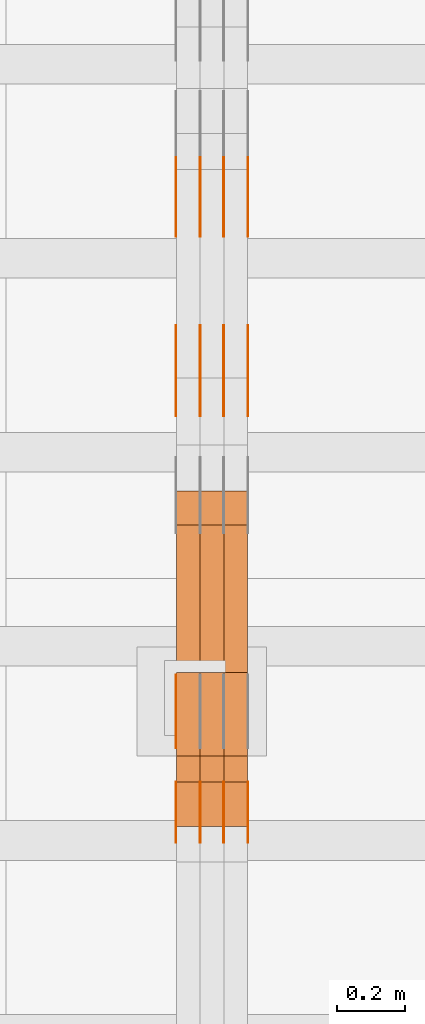
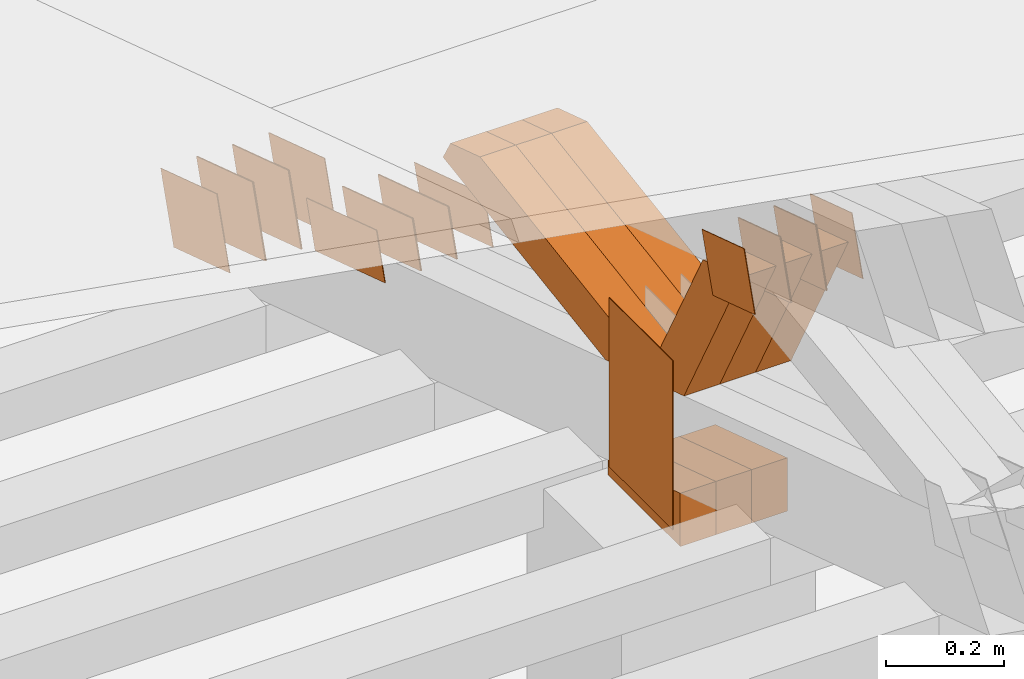
# One storey, part 106 of 385: 28 proxies.
"""IFC2X3 building model written with IfcOpenShell, lengths in millimetres."""

from ifc_helpers import new_model, entity, si_unit, converted_unit, derived_unit, direction, frame, origin, origin_2d_with_axis, place, context, subcontext, project, spatial, polyline, rectangle, outline, extrude, source, transform, mapped, material, type_object, type_shapes, element, save


model = new_model("IFC2X3")

# Units and contexts
model_context = context("Model", 3, precision=0.01, world=origin(), true_north=direction((6.12303176911189e-17, 1.0)))
body_context = subcontext(model_context, "Body", "Model", "MODEL_VIEW")
ifc_project = project(units=[si_unit("LENGTHUNIT", "METRE", prefix="MILLI"), si_unit("AREAUNIT", "SQUARE_METRE"), si_unit("VOLUMEUNIT", "CUBIC_METRE"), converted_unit("PLANEANGLEUNIT", "DEGREE", entity("IfcRatioMeasure", 0.0174532925199433), si_unit("PLANEANGLEUNIT", "RADIAN"), dimensions=[0, 0, 0, 0, 0, 0, 0]), si_unit("MASSUNIT", "GRAM", prefix="KILO"), derived_unit("MASSDENSITYUNIT", [(si_unit("MASSUNIT", "GRAM", prefix="KILO"), 1), (si_unit("LENGTHUNIT", "METRE"), -3)]), si_unit("TIMEUNIT", "SECOND"), si_unit("FREQUENCYUNIT", "HERTZ"), si_unit("THERMODYNAMICTEMPERATUREUNIT", "DEGREE_CELSIUS"), derived_unit("THERMALTRANSMITTANCEUNIT", [(si_unit("MASSUNIT", "GRAM", prefix="KILO"), 1), (si_unit("THERMODYNAMICTEMPERATUREUNIT", "KELVIN"), -1), (si_unit("TIMEUNIT", "SECOND"), -3)]), derived_unit("VOLUMETRICFLOWRATEUNIT", [(si_unit("LENGTHUNIT", "METRE"), 3), (si_unit("TIMEUNIT", "SECOND"), -1)]), si_unit("ELECTRICCURRENTUNIT", "AMPERE"), si_unit("ELECTRICVOLTAGEUNIT", "VOLT"), si_unit("POWERUNIT", "WATT"), si_unit("FORCEUNIT", "NEWTON", prefix="KILO"), si_unit("ILLUMINANCEUNIT", "LUX"), si_unit("LUMINOUSFLUXUNIT", "LUMEN"), si_unit("LUMINOUSINTENSITYUNIT", "CANDELA"), derived_unit("USERDEFINED", [(si_unit("MASSUNIT", "GRAM", prefix="KILO"), -1), (si_unit("LENGTHUNIT", "METRE"), -2), (si_unit("TIMEUNIT", "SECOND"), 3), (si_unit("LUMINOUSFLUXUNIT", "LUMEN"), 1)]), derived_unit("LINEARVELOCITYUNIT", [(si_unit("LENGTHUNIT", "METRE"), 1), (si_unit("TIMEUNIT", "SECOND"), -1)]), si_unit("PRESSUREUNIT", "PASCAL"), derived_unit("USERDEFINED", [(si_unit("LENGTHUNIT", "METRE"), -2), (si_unit("MASSUNIT", "GRAM", prefix="KILO"), 1), (si_unit("TIMEUNIT", "SECOND"), -2)])], contexts=[model_context])

# Site, building, storey
site_placement = place(None, origin())
site = spatial("IfcSite", under=ifc_project, at=site_placement, CompositionType="ELEMENT")
building_placement = place(site_placement, origin())
building = spatial("IfcBuilding", under=site, at=building_placement, CompositionType="ELEMENT")
storey_placement = place(building_placement, origin())
storey = spatial("IfcBuildingStorey", under=building, at=storey_placement, Name="Default", CompositionType="ELEMENT", Elevation=0.0)

# Proxies
ifc_material_1 = material(Name="IfcSurfaceStyle #204694")
building_element_proxy_type_1 = type_object("IfcBuildingElementProxyType", PredefinedType="NOTDEFINED", material=ifc_material_1)
shared_shape_1 = source(origin(), body_context, "Body", "SweptSolid", [
    extrude(outline(polyline([(-125.00031378339, -47.9999612158856), (125.000225258022, -47.9999612158856), (124.999811678525, 47.9999612158856), (-124.999723153156, 47.9999612158856), (-125.00031378339, -47.9999612158856)])), frame((125.000225258022, 48.0000091013474, 0.0), z_axis=(0.0, 0.0, 1.0), x_axis=(-1.0, 0.0, 0.0)), (0.0, 0.0, 1.0), 1.3),
])
type_shapes(building_element_proxy_type_1, [shared_shape_1])
proxy_1_placement = place(building_placement, frame((15386.3, 18456.8597683375, 2657.46691321253), z_axis=(-1.0, 0.0, 0.0), x_axis=(0.0, -0.951056516295124, 0.309016994375039)))
element("IfcBuildingElementProxy", 1, at=proxy_1_placement, inside=storey, type_object=building_element_proxy_type_1, material=ifc_material_1, context=body_context, shape_type="MappedRepresentation", body=[
    mapped(shared_shape_1, transform((0.0, 0.0, 0.0), scale=1.0)),
])
ifc_material_2 = material(Name="IfcSurfaceStyle #204637")
building_element_proxy_type_2 = type_object("IfcBuildingElementProxyType", PredefinedType="NOTDEFINED", material=ifc_material_2)
shared_shape_2 = source(origin(), body_context, "Body", "SweptSolid", [
    extrude(outline(polyline([(-125.00031378339, -47.9999612158856), (125.000225258022, -47.9999612158856), (124.999811678525, 47.9999612158856), (-124.999723153156, 47.9999612158856), (-125.00031378339, -47.9999612158856)])), frame((125.000225258022, 48.0000091013474, 0.0), z_axis=(0.0, 0.0, 1.0), x_axis=(-1.0, 0.0, 0.0)), (0.0, 0.0, 1.0), 1.3),
])
type_shapes(building_element_proxy_type_2, [shared_shape_2])
proxy_2_placement = place(building_placement, frame((15315.0, 18456.8597683375, 2657.46691321253), z_axis=(-1.0, 0.0, 0.0), x_axis=(0.0, -0.951056516295124, 0.309016994375039)))
element("IfcBuildingElementProxy", 2, at=proxy_2_placement, inside=storey, type_object=building_element_proxy_type_2, material=ifc_material_2, context=body_context, shape_type="MappedRepresentation", body=[
    mapped(shared_shape_2, transform((0.0, 0.0, 0.0), scale=1.0)),
])
ifc_material_3 = material(Name="IfcSurfaceStyle #204580")
building_element_proxy_type_3 = type_object("IfcBuildingElementProxyType", PredefinedType="NOTDEFINED", material=ifc_material_3)
shared_shape_3 = source(origin(), body_context, "Body", "SweptSolid", [
    extrude(outline(polyline([(-125.00031378339, -47.9999612158856), (125.000225258022, -47.9999612158856), (124.999811678525, 47.9999612158856), (-124.999723153156, 47.9999612158856), (-125.00031378339, -47.9999612158856)])), frame((125.000225258022, 48.0000091013474, 0.0), z_axis=(0.0, 0.0, 1.0), x_axis=(-1.0, 0.0, 0.0)), (0.0, 0.0, 1.0), 1.3),
])
type_shapes(building_element_proxy_type_3, [shared_shape_3])
proxy_3_placement = place(building_placement, frame((15316.3, 18456.8597683375, 2657.46691321253), z_axis=(-1.0, 0.0, 0.0), x_axis=(0.0, -0.951056516295124, 0.309016994375039)))
element("IfcBuildingElementProxy", 3, at=proxy_3_placement, inside=storey, type_object=building_element_proxy_type_3, material=ifc_material_3, context=body_context, shape_type="MappedRepresentation", body=[
    mapped(shared_shape_3, transform((0.0, 0.0, 0.0), scale=1.0)),
])
ifc_material_4 = material(Name="IfcSurfaceStyle #204523")
building_element_proxy_type_4 = type_object("IfcBuildingElementProxyType", PredefinedType="NOTDEFINED", material=ifc_material_4)
shared_shape_4 = source(origin(), body_context, "Body", "SweptSolid", [
    extrude(outline(polyline([(-125.00031378339, -47.9999612158856), (125.000225258022, -47.9999612158856), (124.999811678525, 47.9999612158856), (-124.999723153156, 47.9999612158856), (-125.00031378339, -47.9999612158856)])), frame((125.000225258022, 48.0000091013474, 0.0), z_axis=(0.0, 0.0, 1.0), x_axis=(-1.0, 0.0, 0.0)), (0.0, 0.0, 1.0), 1.29999999999998),
])
type_shapes(building_element_proxy_type_4, [shared_shape_4])
proxy_4_placement = place(building_placement, frame((15245.0, 18456.8597683375, 2657.46691321253), z_axis=(-1.0, 0.0, 0.0), x_axis=(0.0, -0.951056516295124, 0.309016994375039)))
element("IfcBuildingElementProxy", 4, at=proxy_4_placement, inside=storey, type_object=building_element_proxy_type_4, material=ifc_material_4, context=body_context, shape_type="MappedRepresentation", body=[
    mapped(shared_shape_4, transform((0.0, 0.0, 0.0), scale=1.0)),
])
ifc_material_5 = material(Name="IfcSurfaceStyle #204466")
building_element_proxy_type_5 = type_object("IfcBuildingElementProxyType", PredefinedType="NOTDEFINED", material=ifc_material_5)
shared_shape_5 = source(origin(), body_context, "Body", "SweptSolid", [
    extrude(outline(polyline([(-125.00031378339, -47.9999612158856), (125.000225258022, -47.9999612158856), (124.999811678525, 47.9999612158856), (-124.999723153156, 47.9999612158856), (-125.00031378339, -47.9999612158856)])), frame((125.000225258022, 48.0000091013474, 0.0), z_axis=(0.0, 0.0, 1.0), x_axis=(-1.0, 0.0, 0.0)), (0.0, 0.0, 1.0), 1.29999999999998),
])
type_shapes(building_element_proxy_type_5, [shared_shape_5])
proxy_5_placement = place(building_placement, frame((15246.3, 18456.8597683375, 2657.46691321253), z_axis=(-1.0, 0.0, 0.0), x_axis=(0.0, -0.951056516295124, 0.309016994375039)))
element("IfcBuildingElementProxy", 5, at=proxy_5_placement, inside=storey, type_object=building_element_proxy_type_5, material=ifc_material_5, context=body_context, shape_type="MappedRepresentation", body=[
    mapped(shared_shape_5, transform((0.0, 0.0, 0.0), scale=1.0)),
])
ifc_material_6 = material(Name="IfcSurfaceStyle #204409")
building_element_proxy_type_6 = type_object("IfcBuildingElementProxyType", PredefinedType="NOTDEFINED", material=ifc_material_6)
shared_shape_6 = source(origin(), body_context, "Body", "SweptSolid", [
    extrude(outline(polyline([(-125.00031378339, -47.9999612158856), (125.000225258022, -47.9999612158856), (124.999811678525, 47.9999612158856), (-124.999723153156, 47.9999612158856), (-125.00031378339, -47.9999612158856)])), frame((125.000225258022, 48.0000091013474, 0.0), z_axis=(0.0, 0.0, 1.0), x_axis=(-1.0, 0.0, 0.0)), (0.0, 0.0, 1.0), 1.29999999999998),
])
type_shapes(building_element_proxy_type_6, [shared_shape_6])
proxy_6_placement = place(building_placement, frame((15175.0, 18456.8597683375, 2657.46691321253), z_axis=(-1.0, 0.0, 0.0), x_axis=(0.0, -0.951056516295124, 0.309016994375039)))
element("IfcBuildingElementProxy", 6, at=proxy_6_placement, inside=storey, type_object=building_element_proxy_type_6, material=ifc_material_6, context=body_context, shape_type="MappedRepresentation", body=[
    mapped(shared_shape_6, transform((0.0, 0.0, 0.0), scale=1.0)),
])
ifc_material_7 = material(Name="IfcSurfaceStyle #202984")
building_element_proxy_type_7 = type_object("IfcBuildingElementProxyType", PredefinedType="NOTDEFINED", material=ifc_material_7)
shared_shape_7 = source(origin(), body_context, "Body", "SweptSolid", [
    extrude(outline(polyline([(-99.999796294464, -72.0000050220467), (99.9998768370438, -72.0000050220467), (100.000260677528, 72.0000050220467), (-100.000341220108, 72.0000050220467), (-99.999796294464, -72.0000050220467)])), frame((100.000260677528, 72.0000050220467, 0.0), z_axis=(0.0, 0.0, 1.0), x_axis=(-1.0, 0.0, 0.0)), (0.0, 0.0, 1.0), 1.3),
])
type_shapes(building_element_proxy_type_7, [shared_shape_7])
proxy_7_placement = place(building_placement, frame((15386.3, 18936.3876569477, 2373.90613192527), z_axis=(-1.0, 0.0, 0.0), x_axis=(0.0, -0.951056516295124, 0.309016994375039)))
element("IfcBuildingElementProxy", 7, at=proxy_7_placement, inside=storey, type_object=building_element_proxy_type_7, material=ifc_material_7, context=body_context, shape_type="MappedRepresentation", body=[
    mapped(shared_shape_7, transform((0.0, 0.0, 0.0), scale=1.0)),
])
ifc_material_8 = material(Name="IfcSurfaceStyle #202927")
building_element_proxy_type_8 = type_object("IfcBuildingElementProxyType", PredefinedType="NOTDEFINED", material=ifc_material_8)
shared_shape_8 = source(origin(), body_context, "Body", "SweptSolid", [
    extrude(outline(polyline([(-99.999796294464, -72.0000050220467), (99.9998768370438, -72.0000050220467), (100.000260677528, 72.0000050220467), (-100.000341220108, 72.0000050220467), (-99.999796294464, -72.0000050220467)])), frame((100.000260677528, 72.0000050220467, 0.0), z_axis=(0.0, 0.0, 1.0), x_axis=(-1.0, 0.0, 0.0)), (0.0, 0.0, 1.0), 1.3),
])
type_shapes(building_element_proxy_type_8, [shared_shape_8])
proxy_8_placement = place(building_placement, frame((15315.0, 18936.3876569477, 2373.90613192527), z_axis=(-1.0, 0.0, 0.0), x_axis=(0.0, -0.951056516295124, 0.309016994375039)))
element("IfcBuildingElementProxy", 8, at=proxy_8_placement, inside=storey, type_object=building_element_proxy_type_8, material=ifc_material_8, context=body_context, shape_type="MappedRepresentation", body=[
    mapped(shared_shape_8, transform((0.0, 0.0, 0.0), scale=1.0)),
])
ifc_material_9 = material(Name="IfcSurfaceStyle #202870")
building_element_proxy_type_9 = type_object("IfcBuildingElementProxyType", PredefinedType="NOTDEFINED", material=ifc_material_9)
shared_shape_9 = source(origin(), body_context, "Body", "SweptSolid", [
    extrude(outline(polyline([(-99.999796294464, -72.0000050220467), (99.9998768370438, -72.0000050220467), (100.000260677528, 72.0000050220467), (-100.000341220108, 72.0000050220467), (-99.999796294464, -72.0000050220467)])), frame((100.000260677528, 72.0000050220467, 0.0), z_axis=(0.0, 0.0, 1.0), x_axis=(-1.0, 0.0, 0.0)), (0.0, 0.0, 1.0), 1.3),
])
type_shapes(building_element_proxy_type_9, [shared_shape_9])
proxy_9_placement = place(building_placement, frame((15316.3, 18936.3876569477, 2373.90613192527), z_axis=(-1.0, 0.0, 0.0), x_axis=(0.0, -0.951056516295124, 0.309016994375039)))
element("IfcBuildingElementProxy", 9, at=proxy_9_placement, inside=storey, type_object=building_element_proxy_type_9, material=ifc_material_9, context=body_context, shape_type="MappedRepresentation", body=[
    mapped(shared_shape_9, transform((0.0, 0.0, 0.0), scale=1.0)),
])
ifc_material_10 = material(Name="IfcSurfaceStyle #202813")
building_element_proxy_type_10 = type_object("IfcBuildingElementProxyType", PredefinedType="NOTDEFINED", material=ifc_material_10)
shared_shape_10 = source(origin(), body_context, "Body", "SweptSolid", [
    extrude(outline(polyline([(-99.999796294464, -72.0000050220467), (99.9998768370438, -72.0000050220467), (100.000260677528, 72.0000050220467), (-100.000341220108, 72.0000050220467), (-99.999796294464, -72.0000050220467)])), frame((100.000260677528, 72.0000050220467, 0.0), z_axis=(0.0, 0.0, 1.0), x_axis=(-1.0, 0.0, 0.0)), (0.0, 0.0, 1.0), 1.29999999999998),
])
type_shapes(building_element_proxy_type_10, [shared_shape_10])
proxy_10_placement = place(building_placement, frame((15245.0, 18936.3876569477, 2373.90613192527), z_axis=(-1.0, 0.0, 0.0), x_axis=(0.0, -0.951056516295124, 0.309016994375039)))
element("IfcBuildingElementProxy", 10, at=proxy_10_placement, inside=storey, type_object=building_element_proxy_type_10, material=ifc_material_10, context=body_context, shape_type="MappedRepresentation", body=[
    mapped(shared_shape_10, transform((0.0, 0.0, 0.0), scale=1.0)),
])
ifc_material_11 = material(Name="IfcSurfaceStyle #202756")
building_element_proxy_type_11 = type_object("IfcBuildingElementProxyType", PredefinedType="NOTDEFINED", material=ifc_material_11)
shared_shape_11 = source(origin(), body_context, "Body", "SweptSolid", [
    extrude(outline(polyline([(-99.999796294464, -72.0000050220467), (99.9998768370438, -72.0000050220467), (100.000260677528, 72.0000050220467), (-100.000341220108, 72.0000050220467), (-99.999796294464, -72.0000050220467)])), frame((100.000260677528, 72.0000050220467, 0.0), z_axis=(0.0, 0.0, 1.0), x_axis=(-1.0, 0.0, 0.0)), (0.0, 0.0, 1.0), 1.29999999999998),
])
type_shapes(building_element_proxy_type_11, [shared_shape_11])
proxy_11_placement = place(building_placement, frame((15246.3, 18936.3876569477, 2373.90613192527), z_axis=(-1.0, 0.0, 0.0), x_axis=(0.0, -0.951056516295124, 0.309016994375039)))
element("IfcBuildingElementProxy", 11, at=proxy_11_placement, inside=storey, type_object=building_element_proxy_type_11, material=ifc_material_11, context=body_context, shape_type="MappedRepresentation", body=[
    mapped(shared_shape_11, transform((0.0, 0.0, 0.0), scale=1.0)),
])
ifc_material_12 = material(Name="IfcSurfaceStyle #202699")
building_element_proxy_type_12 = type_object("IfcBuildingElementProxyType", PredefinedType="NOTDEFINED", material=ifc_material_12)
shared_shape_12 = source(origin(), body_context, "Body", "SweptSolid", [
    extrude(outline(polyline([(-99.999796294464, -72.0000050220467), (99.9998768370438, -72.0000050220467), (100.000260677528, 72.0000050220467), (-100.000341220108, 72.0000050220467), (-99.999796294464, -72.0000050220467)])), frame((100.000260677528, 72.0000050220467, 0.0), z_axis=(0.0, 0.0, 1.0), x_axis=(-1.0, 0.0, 0.0)), (0.0, 0.0, 1.0), 1.29999999999999),
])
type_shapes(building_element_proxy_type_12, [shared_shape_12])
proxy_12_placement = place(building_placement, frame((15175.0, 18936.3876569477, 2373.90613192527), z_axis=(-1.0, 0.0, 0.0), x_axis=(0.0, -0.951056516295124, 0.309016994375039)))
element("IfcBuildingElementProxy", 12, at=proxy_12_placement, inside=storey, type_object=building_element_proxy_type_12, material=ifc_material_12, context=body_context, shape_type="MappedRepresentation", body=[
    mapped(shared_shape_12, transform((0.0, 0.0, 0.0), scale=1.0)),
])
ifc_material_13 = material(Name="IfcSurfaceStyle #202357")
building_element_proxy_type_13 = type_object("IfcBuildingElementProxyType", PredefinedType="NOTDEFINED", material=ifc_material_13)
shared_shape_13 = source(origin(), body_context, "Body", "SweptSolid", [
    extrude(rectangle(XDim=350.0, YDim=215.999999999984, at=origin_2d_with_axis()), frame((175.0, 108.0, 0.0), z_axis=(0.0, 0.0, 1.0), x_axis=(-1.0, 0.0, 0.0)), (0.0, 0.0, 1.0), 1.29999999999998),
])
type_shapes(building_element_proxy_type_13, [shared_shape_13])
proxy_13_placement = place(building_placement, frame((15175.0, 17459.2939453125, 3165.36425781251), z_axis=(-1.0, 0.0, 0.0), x_axis=(0.0, 0.0, -1.0)))
element("IfcBuildingElementProxy", 13, at=proxy_13_placement, inside=storey, type_object=building_element_proxy_type_13, material=ifc_material_13, context=body_context, shape_type="MappedRepresentation", body=[
    mapped(shared_shape_13, transform((0.0, 0.0, 0.0), scale=1.0)),
])
ifc_material_14 = material(Name="IfcSurfaceStyle #199222")
building_element_proxy_type_14 = type_object("IfcBuildingElementProxyType", PredefinedType="NOTDEFINED", material=ifc_material_14)
shared_shape_14 = source(origin(), body_context, "Body", "SweptSolid", [
    extrude(outline(polyline([(-74.9998605591058, -59.9999264677524), (74.999875428623, -59.9999264677524), (74.9998605591068, 59.9999264677524), (-74.9998754286239, 59.9999264677524), (-74.9998605591058, -59.9999264677524)])), frame((75.0002460484325, 60.0000016373508, 0.0), z_axis=(0.0, 0.0, 1.0), x_axis=(-1.0, 0.0, 0.0)), (0.0, 0.0, 1.0), 1.3),
])
type_shapes(building_element_proxy_type_14, [shared_shape_14])
proxy_14_placement = place(building_placement, frame((15386.3, 17107.0599369346, 3383.82825001787), z_axis=(-1.0, 0.0, 0.0), x_axis=(0.0, -0.951056516295154, 0.309016994374948)))
element("IfcBuildingElementProxy", 14, at=proxy_14_placement, inside=storey, type_object=building_element_proxy_type_14, material=ifc_material_14, context=body_context, shape_type="MappedRepresentation", body=[
    mapped(shared_shape_14, transform((0.0, 0.0, 0.0), scale=1.0)),
])
ifc_material_15 = material(Name="IfcSurfaceStyle #199165")
building_element_proxy_type_15 = type_object("IfcBuildingElementProxyType", PredefinedType="NOTDEFINED", material=ifc_material_15)
shared_shape_15 = source(origin(), body_context, "Body", "SweptSolid", [
    extrude(outline(polyline([(-74.9998605591058, -59.9999264677524), (74.999875428623, -59.9999264677524), (74.9998605591068, 59.9999264677524), (-74.9998754286239, 59.9999264677524), (-74.9998605591058, -59.9999264677524)])), frame((75.0002460484325, 60.0000016373508, 0.0), z_axis=(0.0, 0.0, 1.0), x_axis=(-1.0, 0.0, 0.0)), (0.0, 0.0, 1.0), 1.3),
])
type_shapes(building_element_proxy_type_15, [shared_shape_15])
proxy_15_placement = place(building_placement, frame((15315.0, 17107.0599369346, 3383.82825001787), z_axis=(-1.0, 0.0, 0.0), x_axis=(0.0, -0.951056516295154, 0.309016994374948)))
element("IfcBuildingElementProxy", 15, at=proxy_15_placement, inside=storey, type_object=building_element_proxy_type_15, material=ifc_material_15, context=body_context, shape_type="MappedRepresentation", body=[
    mapped(shared_shape_15, transform((0.0, 0.0, 0.0), scale=1.0)),
])
ifc_material_16 = material(Name="IfcSurfaceStyle #199108")
building_element_proxy_type_16 = type_object("IfcBuildingElementProxyType", PredefinedType="NOTDEFINED", material=ifc_material_16)
shared_shape_16 = source(origin(), body_context, "Body", "SweptSolid", [
    extrude(outline(polyline([(-74.9998605591058, -59.9999264677524), (74.999875428623, -59.9999264677524), (74.9998605591068, 59.9999264677524), (-74.9998754286239, 59.9999264677524), (-74.9998605591058, -59.9999264677524)])), frame((75.0002460484325, 60.0000016373508, 0.0), z_axis=(0.0, 0.0, 1.0), x_axis=(-1.0, 0.0, 0.0)), (0.0, 0.0, 1.0), 1.3),
])
type_shapes(building_element_proxy_type_16, [shared_shape_16])
proxy_16_placement = place(building_placement, frame((15316.3, 17107.0599369346, 3383.82825001787), z_axis=(-1.0, 0.0, 0.0), x_axis=(0.0, -0.951056516295154, 0.309016994374948)))
element("IfcBuildingElementProxy", 16, at=proxy_16_placement, inside=storey, type_object=building_element_proxy_type_16, material=ifc_material_16, context=body_context, shape_type="MappedRepresentation", body=[
    mapped(shared_shape_16, transform((0.0, 0.0, 0.0), scale=1.0)),
])
ifc_material_17 = material(Name="IfcSurfaceStyle #199051")
building_element_proxy_type_17 = type_object("IfcBuildingElementProxyType", PredefinedType="NOTDEFINED", material=ifc_material_17)
shared_shape_17 = source(origin(), body_context, "Body", "SweptSolid", [
    extrude(outline(polyline([(-74.9998605591058, -59.9999264677524), (74.999875428623, -59.9999264677524), (74.9998605591068, 59.9999264677524), (-74.9998754286239, 59.9999264677524), (-74.9998605591058, -59.9999264677524)])), frame((75.0002460484325, 60.0000016373508, 0.0), z_axis=(0.0, 0.0, 1.0), x_axis=(-1.0, 0.0, 0.0)), (0.0, 0.0, 1.0), 1.29999999999999),
])
type_shapes(building_element_proxy_type_17, [shared_shape_17])
proxy_17_placement = place(building_placement, frame((15245.0, 17107.0599369346, 3383.82825001787), z_axis=(-1.0, 0.0, 0.0), x_axis=(0.0, -0.951056516295154, 0.309016994374948)))
element("IfcBuildingElementProxy", 17, at=proxy_17_placement, inside=storey, type_object=building_element_proxy_type_17, material=ifc_material_17, context=body_context, shape_type="MappedRepresentation", body=[
    mapped(shared_shape_17, transform((0.0, 0.0, 0.0), scale=1.0)),
])
ifc_material_18 = material(Name="IfcSurfaceStyle #198994")
building_element_proxy_type_18 = type_object("IfcBuildingElementProxyType", PredefinedType="NOTDEFINED", material=ifc_material_18)
shared_shape_18 = source(origin(), body_context, "Body", "SweptSolid", [
    extrude(outline(polyline([(-74.9998605591058, -59.9999264677524), (74.999875428623, -59.9999264677524), (74.9998605591068, 59.9999264677524), (-74.9998754286239, 59.9999264677524), (-74.9998605591058, -59.9999264677524)])), frame((75.0002460484325, 60.0000016373508, 0.0), z_axis=(0.0, 0.0, 1.0), x_axis=(-1.0, 0.0, 0.0)), (0.0, 0.0, 1.0), 1.29999999999999),
])
type_shapes(building_element_proxy_type_18, [shared_shape_18])
proxy_18_placement = place(building_placement, frame((15246.3, 17107.0599369346, 3383.82825001787), z_axis=(-1.0, 0.0, 0.0), x_axis=(0.0, -0.951056516295154, 0.309016994374948)))
element("IfcBuildingElementProxy", 18, at=proxy_18_placement, inside=storey, type_object=building_element_proxy_type_18, material=ifc_material_18, context=body_context, shape_type="MappedRepresentation", body=[
    mapped(shared_shape_18, transform((0.0, 0.0, 0.0), scale=1.0)),
])
ifc_material_19 = material(Name="IfcSurfaceStyle #198937")
building_element_proxy_type_19 = type_object("IfcBuildingElementProxyType", PredefinedType="NOTDEFINED", material=ifc_material_19)
shared_shape_19 = source(origin(), body_context, "Body", "SweptSolid", [
    extrude(outline(polyline([(-74.9998605591058, -59.9999264677524), (74.999875428623, -59.9999264677524), (74.9998605591068, 59.9999264677524), (-74.9998754286239, 59.9999264677524), (-74.9998605591058, -59.9999264677524)])), frame((75.0002460484325, 60.0000016373508, 0.0), z_axis=(0.0, 0.0, 1.0), x_axis=(-1.0, 0.0, 0.0)), (0.0, 0.0, 1.0), 1.29999999999999),
])
type_shapes(building_element_proxy_type_19, [shared_shape_19])
proxy_19_placement = place(building_placement, frame((15175.0, 17107.0599369346, 3383.82825001787), z_axis=(-1.0, 0.0, 0.0), x_axis=(0.0, -0.951056516295154, 0.309016994374948)))
element("IfcBuildingElementProxy", 19, at=proxy_19_placement, inside=storey, type_object=building_element_proxy_type_19, material=ifc_material_19, context=body_context, shape_type="MappedRepresentation", body=[
    mapped(shared_shape_19, transform((0.0, 0.0, 0.0), scale=1.0)),
])
ifc_material_20 = material(Name="IfcSurfaceStyle #190933")
building_element_proxy_type_20 = type_object("IfcBuildingElementProxyType", Name="T1-E1 190931", PredefinedType="NOTDEFINED", material=ifc_material_20)
shared_shape_20 = source(origin(), body_context, "Body", "SweptSolid", [
    extrude(outline(polyline([(4.4675903320374, -122.500000000001), (35.3350219726624, -122.500000000001), (35.3350219726501, 122.500000000001), (-75.1376342773499, 122.500000000001), (4.4675903320374, -122.500000000001)])), frame((35.3350219726624, 122.50000005215, 0.0), z_axis=(0.0, 0.0, 1.0), x_axis=(-1.0, 0.0, 0.0)), (0.0, 0.0, 1.0), 70.0),
])
type_shapes(building_element_proxy_type_20, [shared_shape_20])
proxy_20_placement = place(building_placement, frame((15385.0, 17220.0, 2794.30932617186), z_axis=(-1.0, 0.0, 0.0), x_axis=(0.0, 0.0, 1.0)))
element("IfcBuildingElementProxy", 20, at=proxy_20_placement, inside=storey, type_object=building_element_proxy_type_20, material=ifc_material_20, Name="T1-E1", context=body_context, shape_type="MappedRepresentation", body=[
    mapped(shared_shape_20, transform((0.0, 0.0, 0.0), scale=1.0)),
])
ifc_material_21 = material(Name="IfcSurfaceStyle #190876")
building_element_proxy_type_21 = type_object("IfcBuildingElementProxyType", Name="T1-E1 190874", PredefinedType="NOTDEFINED", material=ifc_material_21)
shared_shape_21 = source(origin(), body_context, "Body", "SweptSolid", [
    extrude(outline(polyline([(4.4675903320374, -122.500000000001), (35.3350219726624, -122.500000000001), (35.3350219726501, 122.500000000001), (-75.1376342773499, 122.500000000001), (4.4675903320374, -122.500000000001)])), frame((35.3350219726624, 122.50000005215, 0.0), z_axis=(0.0, 0.0, 1.0), x_axis=(-1.0, 0.0, 0.0)), (0.0, 0.0, 1.0), 70.0),
])
type_shapes(building_element_proxy_type_21, [shared_shape_21])
proxy_21_placement = place(building_placement, frame((15315.0, 17220.0, 2794.30932617186), z_axis=(-1.0, 0.0, 0.0), x_axis=(0.0, 0.0, 1.0)))
element("IfcBuildingElementProxy", 21, at=proxy_21_placement, inside=storey, type_object=building_element_proxy_type_21, material=ifc_material_21, Name="T1-E1", context=body_context, shape_type="MappedRepresentation", body=[
    mapped(shared_shape_21, transform((0.0, 0.0, 0.0), scale=1.0)),
])
ifc_material_22 = material(Name="IfcSurfaceStyle #190819")
building_element_proxy_type_22 = type_object("IfcBuildingElementProxyType", Name="T1-E1 190817", PredefinedType="NOTDEFINED", material=ifc_material_22)
shared_shape_22 = source(origin(), body_context, "Body", "SweptSolid", [
    extrude(outline(polyline([(4.4675903320374, -122.500000000001), (35.3350219726624, -122.500000000001), (35.3350219726501, 122.500000000001), (-75.1376342773499, 122.500000000001), (4.4675903320374, -122.500000000001)])), frame((35.3350219726624, 122.50000005215, 0.0), z_axis=(0.0, 0.0, 1.0), x_axis=(-1.0, 0.0, 0.0)), (0.0, 0.0, 1.0), 70.0),
])
type_shapes(building_element_proxy_type_22, [shared_shape_22])
proxy_22_placement = place(building_placement, frame((15245.0, 17220.0, 2794.30932617186), z_axis=(-1.0, 0.0, 0.0), x_axis=(0.0, 0.0, 1.0)))
element("IfcBuildingElementProxy", 22, at=proxy_22_placement, inside=storey, type_object=building_element_proxy_type_22, material=ifc_material_22, Name="T1-E1", context=body_context, shape_type="MappedRepresentation", body=[
    mapped(shared_shape_22, transform((0.0, 0.0, 0.0), scale=1.0)),
])
ifc_material_23 = material(Name="IfcSurfaceStyle #189178")
building_element_proxy_type_23 = type_object("IfcBuildingElementProxyType", Name="T1-W39 189176", PredefinedType="NOTDEFINED", material=ifc_material_23)
shared_shape_23 = source(origin(), body_context, "Body", "SweptSolid", [
    extrude(outline(polyline([(-191.519946663886, -47.499928106579), (188.32936223763, -47.499928106579), (171.597440144109, 0.000249483340993841), (122.102882529753, 47.4998033649085), (-290.509738247605, 47.4998033649085), (-191.519946663886, -47.499928106579)])), frame((188.329593252001, 47.499957247623, 0.0), z_axis=(0.0, 0.0, 1.0), x_axis=(-1.0, 0.0, 0.0)), (0.0, 0.0, 1.0), 70.0),
])
type_shapes(building_element_proxy_type_23, [shared_shape_23])
proxy_23_placement = place(building_placement, frame((15385.0, 17238.5876916597, 3055.56121424762), z_axis=(-1.0, 0.0, 0.0), x_axis=(0.0, -0.472216932390777, 0.881482370080902)))
element("IfcBuildingElementProxy", 23, at=proxy_23_placement, inside=storey, type_object=building_element_proxy_type_23, material=ifc_material_23, Name="T1-W39", context=body_context, shape_type="MappedRepresentation", body=[
    mapped(shared_shape_23, transform((0.0, 0.0, 0.0), scale=1.0)),
])
ifc_material_24 = material(Name="IfcSurfaceStyle #189112")
building_element_proxy_type_24 = type_object("IfcBuildingElementProxyType", Name="T1-W39 189110", PredefinedType="NOTDEFINED", material=ifc_material_24)
shared_shape_24 = source(origin(), body_context, "Body", "SweptSolid", [
    extrude(outline(polyline([(-191.519946663886, -47.499928106579), (188.32936223763, -47.499928106579), (171.597440144109, 0.000249483340993841), (122.102882529753, 47.4998033649085), (-290.509738247605, 47.4998033649085), (-191.519946663886, -47.499928106579)])), frame((188.329593252001, 47.499957247623, 0.0), z_axis=(0.0, 0.0, 1.0), x_axis=(-1.0, 0.0, 0.0)), (0.0, 0.0, 1.0), 70.0),
])
type_shapes(building_element_proxy_type_24, [shared_shape_24])
proxy_24_placement = place(building_placement, frame((15315.0, 17238.5876916597, 3055.56121424762), z_axis=(-1.0, 0.0, 0.0), x_axis=(0.0, -0.472216932390777, 0.881482370080902)))
element("IfcBuildingElementProxy", 24, at=proxy_24_placement, inside=storey, type_object=building_element_proxy_type_24, material=ifc_material_24, Name="T1-W39", context=body_context, shape_type="MappedRepresentation", body=[
    mapped(shared_shape_24, transform((0.0, 0.0, 0.0), scale=1.0)),
])
ifc_material_25 = material(Name="IfcSurfaceStyle #189046")
building_element_proxy_type_25 = type_object("IfcBuildingElementProxyType", Name="T1-W39 189044", PredefinedType="NOTDEFINED", material=ifc_material_25)
shared_shape_25 = source(origin(), body_context, "Body", "SweptSolid", [
    extrude(outline(polyline([(-191.519946663886, -47.499928106579), (188.32936223763, -47.499928106579), (171.597440144109, 0.000249483340993841), (122.102882529753, 47.4998033649085), (-290.509738247605, 47.4998033649085), (-191.519946663886, -47.499928106579)])), frame((188.329593252001, 47.499957247623, 0.0), z_axis=(0.0, 0.0, 1.0), x_axis=(-1.0, 0.0, 0.0)), (0.0, 0.0, 1.0), 70.0),
])
type_shapes(building_element_proxy_type_25, [shared_shape_25])
proxy_25_placement = place(building_placement, frame((15245.0, 17238.5876916597, 3055.56121424762), z_axis=(-1.0, 0.0, 0.0), x_axis=(0.0, -0.472216932390777, 0.881482370080902)))
element("IfcBuildingElementProxy", 25, at=proxy_25_placement, inside=storey, type_object=building_element_proxy_type_25, material=ifc_material_25, Name="T1-W39", context=body_context, shape_type="MappedRepresentation", body=[
    mapped(shared_shape_25, transform((0.0, 0.0, 0.0), scale=1.0)),
])
ifc_material_26 = material(Name="IfcSurfaceStyle #188782")
building_element_proxy_type_26 = type_object("IfcBuildingElementProxyType", Name="T1-W10 188780", PredefinedType="NOTDEFINED", material=ifc_material_26)
shared_shape_26 = source(origin(), body_context, "Body", "SweptSolid", [
    extrude(outline(polyline([(-459.546036710757, -47.5000436364511), (174.689450869018, -47.5000436364511), (268.831081103959, 0.00011114562912502), (287.286350706789, 47.4999880636365), (-271.260845969009, 47.4999880636366), (-459.546036710757, -47.5000436364511)])), frame((287.286768781132, 47.5001637448091, 0.0), z_axis=(0.0, 0.0, 1.0), x_axis=(-1.0, 0.0, 0.0)), (0.0, 0.0, 1.0), 70.0),
])
type_shapes(building_element_proxy_type_26, [shared_shape_26])
proxy_26_placement = place(building_placement, frame((15385.0, 18025.1410649788, 3112.76453857986), z_axis=(-1.0, 0.0, 0.0), x_axis=(0.0, -0.988299196256916, -0.152527698068035)))
element("IfcBuildingElementProxy", 26, at=proxy_26_placement, inside=storey, type_object=building_element_proxy_type_26, material=ifc_material_26, Name="T1-W10", context=body_context, shape_type="MappedRepresentation", body=[
    mapped(shared_shape_26, transform((0.0, 0.0, 0.0), scale=1.0)),
])
ifc_material_27 = material(Name="IfcSurfaceStyle #188716")
building_element_proxy_type_27 = type_object("IfcBuildingElementProxyType", Name="T1-W10 188714", PredefinedType="NOTDEFINED", material=ifc_material_27)
shared_shape_27 = source(origin(), body_context, "Body", "SweptSolid", [
    extrude(outline(polyline([(-459.546036710757, -47.5000436364511), (174.689450869018, -47.5000436364511), (268.831081103959, 0.00011114562912502), (287.286350706789, 47.4999880636365), (-271.260845969009, 47.4999880636366), (-459.546036710757, -47.5000436364511)])), frame((287.286768781132, 47.5001637448091, 0.0), z_axis=(0.0, 0.0, 1.0), x_axis=(-1.0, 0.0, 0.0)), (0.0, 0.0, 1.0), 70.0),
])
type_shapes(building_element_proxy_type_27, [shared_shape_27])
proxy_27_placement = place(building_placement, frame((15315.0, 18025.1410649788, 3112.76453857986), z_axis=(-1.0, 0.0, 0.0), x_axis=(0.0, -0.988299196256916, -0.152527698068035)))
element("IfcBuildingElementProxy", 27, at=proxy_27_placement, inside=storey, type_object=building_element_proxy_type_27, material=ifc_material_27, Name="T1-W10", context=body_context, shape_type="MappedRepresentation", body=[
    mapped(shared_shape_27, transform((0.0, 0.0, 0.0), scale=1.0)),
])
ifc_material_28 = material(Name="IfcSurfaceStyle #188650")
building_element_proxy_type_28 = type_object("IfcBuildingElementProxyType", Name="T1-W10 188648", PredefinedType="NOTDEFINED", material=ifc_material_28)
shared_shape_28 = source(origin(), body_context, "Body", "SweptSolid", [
    extrude(outline(polyline([(-459.546036710757, -47.5000436364511), (174.689450869018, -47.5000436364511), (268.831081103959, 0.00011114562912502), (287.286350706789, 47.4999880636365), (-271.260845969009, 47.4999880636366), (-459.546036710757, -47.5000436364511)])), frame((287.286768781132, 47.5001637448091, 0.0), z_axis=(0.0, 0.0, 1.0), x_axis=(-1.0, 0.0, 0.0)), (0.0, 0.0, 1.0), 70.0),
])
type_shapes(building_element_proxy_type_28, [shared_shape_28])
proxy_28_placement = place(building_placement, frame((15245.0, 18025.1410649788, 3112.76453857986), z_axis=(-1.0, 0.0, 0.0), x_axis=(0.0, -0.988299196256916, -0.152527698068035)))
element("IfcBuildingElementProxy", 28, at=proxy_28_placement, inside=storey, type_object=building_element_proxy_type_28, material=ifc_material_28, Name="T1-W10", context=body_context, shape_type="MappedRepresentation", body=[
    mapped(shared_shape_28, transform((0.0, 0.0, 0.0), scale=1.0)),
])

save(model, "model.ifc")
